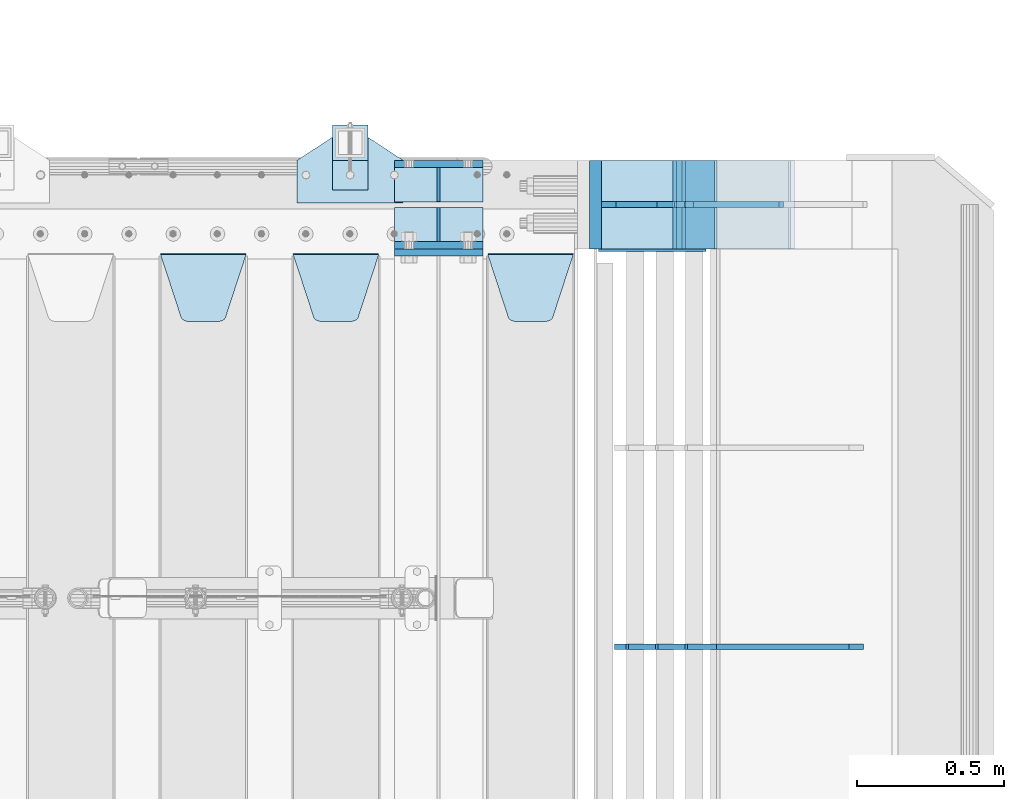
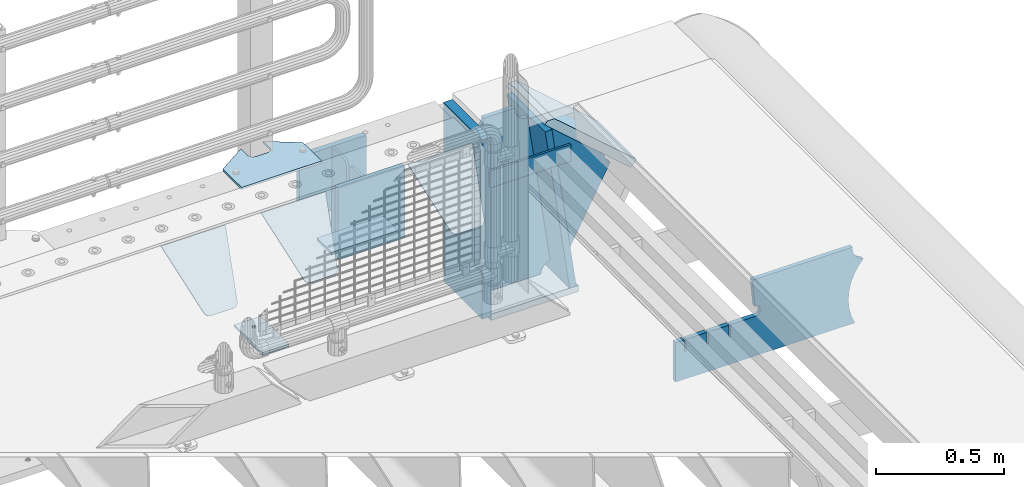
# One storey, part 226 of 242: 21 plates.
"""IFC2X3 building model written with IfcOpenShell, lengths in millimetres."""

from ifc_helpers import new_model, si_unit, frame, origin_with_axes, place, context, subcontext, project, spatial, faceted_brep, material, type_object, element, save


model = new_model("IFC2X3")

# Units and contexts
model_context = context("Model", 3, precision=1e-05, world=origin_with_axes())
body_context = subcontext(model_context, "Body", "Model", "MODEL_VIEW")
ifc_project = project(units=[si_unit("LENGTHUNIT", "METRE", prefix="MILLI"), si_unit("AREAUNIT", "SQUARE_METRE"), si_unit("VOLUMEUNIT", "CUBIC_METRE"), si_unit("MASSUNIT", "GRAM", prefix="KILO"), si_unit("TIMEUNIT", "SECOND"), si_unit("PLANEANGLEUNIT", "RADIAN"), si_unit("SOLIDANGLEUNIT", "STERADIAN"), si_unit("THERMODYNAMICTEMPERATUREUNIT", "DEGREE_CELSIUS"), si_unit("LUMINOUSINTENSITYUNIT", "LUMEN")], contexts=[model_context])

# Site, building, storey
site_placement = place(None, origin_with_axes())
site = spatial("IfcSite", under=ifc_project, at=site_placement, CompositionType="ELEMENT")
building_placement = place(site_placement, origin_with_axes())
building = spatial("IfcBuilding", under=site, at=building_placement, Name="Standard", CompositionType="ELEMENT")
storey_placement = place(building_placement, origin_with_axes())
storey = spatial("IfcBuildingStorey", under=building, at=storey_placement, Name="Undefined", CompositionType="ELEMENT", Elevation=0.0)

# Plates
ifc_material_1 = material(Name="STEEL/S355J2")
plate_type_1 = type_object("IfcPlateType", PredefinedType="NOTDEFINED")
plate_1_placement = place(storey_placement, frame((-23012.0, -17995.0, 5.00000000004911), z_axis=(0.0, 1.0, 0.0), x_axis=(1.0, 0.0, 0.0)))
element("IfcPlate", 1, at=plate_1_placement, inside=storey, type_object=plate_type_1, material=ifc_material_1, context=body_context, shape_type="Brep", body=[
    faceted_brep([(0.0, -5.0, 0.0), (2.31396552408114e-06, -5.0, 145.0), (2.31396552408114e-06, 5.0, 145.0), (0.0, 5.0, 0.0), (130.0, -5.0, 230.0), (130.0, 5.0, 230.0), (130.0, -5.0, 180.0), (130.0, 5.0, 180.0), (130.48036798992, -5.0, 175.122741949595), (130.48036798992, 5.0, 175.122741949595), (131.903011687216, -5.0, 170.432914190871), (131.903011687216, 5.0, 170.432914190871), (134.213259692435, -5.0, 166.110744174512), (134.213259692435, 5.0, 166.110744174512), (137.322330470335, -5.0, 162.322330470335), (137.322330470335, 5.0, 162.322330470335), (141.110744174512, -5.0, 159.213259692435), (141.110744174512, 5.0, 159.213259692435), (145.432914190871, -5.0, 156.903011687216), (145.432914190871, 5.0, 156.903011687216), (150.122741949595, -5.0, 155.48036798992), (150.122741949595, 5.0, 155.48036798992), (155.0, -5.0, 155.0), (155.0, 5.0, 155.0), (205.0, -5.0, 155.0), (205.0, 5.0, 155.0), (209.877258050405, -5.0, 155.48036798992), (209.877258050405, 5.0, 155.48036798992), (214.567085809129, -5.0, 156.903011687216), (214.567085809129, 5.0, 156.903011687216), (218.889255825488, -5.0, 159.213259692435), (218.889255825488, 5.0, 159.213259692435), (222.677669529665, -5.0, 162.322330470335), (222.677669529665, 5.0, 162.322330470335), (225.786740307565, -5.0, 166.110744174512), (225.786740307565, 5.0, 166.110744174512), (228.096988312784, -5.0, 170.432914190871), (228.096988312784, 5.0, 170.432914190871), (229.51963201008, -5.0, 175.122741949595), (229.51963201008, 5.0, 175.122741949595), (230.0, -5.0, 180.0), (230.0, 5.0, 180.0), (230.0, -5.0, 230.0), (230.0, 5.0, 230.0), (360.0, -5.0, 145.0), (360.0, 5.0, 145.0), (360.0, -5.0, -7.27595761418343e-12), (360.0, 5.0, -7.27595761418343e-12)], [[[0, 1, 2, 3]], [[1, 4, 5, 2]], [[4, 6, 7, 5]], [[6, 8, 9, 7]], [[8, 10, 11, 9]], [[10, 12, 13, 11]], [[12, 14, 15, 13]], [[14, 16, 17, 15]], [[16, 18, 19, 17]], [[18, 20, 21, 19]], [[20, 22, 23, 21]], [[22, 24, 25, 23]], [[24, 26, 27, 25]], [[26, 28, 29, 27]], [[28, 30, 31, 29]], [[30, 32, 33, 31]], [[32, 34, 35, 33]], [[34, 36, 37, 35]], [[36, 38, 39, 37]], [[38, 40, 41, 39]], [[40, 42, 43, 41]], [[42, 44, 45, 43]], [[44, 46, 47, 45]], [[46, 0, 3, 47]], [[5, 7, 9, 11, 13, 15, 17, 19, 21, 23, 25, 27, 29, 31, 33, 35, 37, 39, 41, 43, 45, 47, 3, 2]], [[46, 44, 42, 40, 38, 36, 34, 32, 30, 28, 26, 24, 22, 20, 18, 16, 14, 12, 10, 8, 6, 4, 1, 0]]]),
])
plate_type_2 = type_object("IfcPlateType", PredefinedType="NOTDEFINED")
plate_2_placement = place(storey_placement, frame((-22891.9999999999, -17949.9999999998, -850.000000000002), z_axis=(0.0, 1.0, 0.0), x_axis=(1.0, 0.0, 0.0)))
element("IfcPlate", 2, at=plate_2_placement, inside=storey, type_object=plate_type_2, material=ifc_material_1, context=body_context, shape_type="Brep", body=[
    faceted_brep([(66.3639610305399, -5.0, 163.636038969114), (66.3639610305399, 5.0, 163.636038969114), (59.9999999998618, 5.0, 160.999999999793), (59.9999999998618, -5.0, 160.999999999793), (53.6360389691836, 5.0, 163.636038969114), (53.6360389691836, -5.0, 163.636038969114), (50.9999999998618, 5.0, 169.999999999793), (50.9999999998618, -5.0, 169.999999999793), (53.6360389691836, 5.0, 176.363961030471), (53.6360389691836, -5.0, 176.363961030471), (59.9999999998618, 5.0, 178.999999999793), (59.9999999998618, -5.0, 178.999999999793), (66.3639610305399, 5.0, 176.363961030471), (66.3639610305399, -5.0, 176.363961030471), (68.9999999998618, 5.0, 169.999999999793), (68.9999999998618, -5.0, 169.999999999793), (120.0, -5.0, 0.0), (120.0, -5.0, 220.0), (0.0, -5.0, 220.0), (0.0, -5.0, 0.0), (0.0, 5.0, 0.0), (120.0, 5.0, 0.0), (120.0, 5.0, 220.0), (0.0, 5.0, 220.0)], [[[0, 1, 2, 3]], [[3, 2, 4, 5]], [[5, 4, 6, 7]], [[7, 6, 8, 9]], [[9, 8, 10, 11]], [[11, 10, 12, 13]], [[13, 12, 14, 15]], [[15, 14, 1, 0]], [[16, 17, 18, 19], [11, 13, 15, 0, 3, 5, 7, 9]], [[16, 19, 20, 21]], [[17, 16, 21, 22]], [[18, 17, 22, 23]], [[19, 18, 23, 20]], [[22, 21, 20, 23], [2, 1, 14, 12, 10, 8, 6, 4]]]),
])
plate_type_3 = type_object("IfcPlateType", PredefinedType="NOTDEFINED")
plate_3_placement = place(storey_placement, frame((-22891.9999999999, -17949.9999999998, -857.500000000002), z_axis=(0.0, 1.0, 0.0), x_axis=(1.0, 0.0, 0.0)))
element("IfcPlate", 3, at=plate_3_placement, inside=storey, type_object=plate_type_3, material=ifc_material_1, context=body_context, shape_type="Brep", body=[
    faceted_brep([(0.0, -2.5, 0.0), (0.0, -2.5, 100.0), (0.0, 2.5, 100.0), (0.0, 2.5, 0.0), (120.0, -2.5, 100.0), (120.0, 2.5, 100.0), (120.0, -2.5, 0.0), (120.0, 2.5, 0.0)], [[[0, 1, 2, 3]], [[1, 4, 5, 2]], [[4, 6, 7, 5]], [[6, 0, 3, 7]], [[5, 7, 3, 2]], [[6, 4, 1, 0]]]),
])
ifc_material_2 = material(Name="STEEL/S355N")
plate_type_4 = type_object("IfcPlateType", PredefinedType="NOTDEFINED")
plate_4_placement = place(storey_placement, frame((-22682.0, -18162.5, -340.000000000044), z_axis=(0.0, 0.0, 1.0), x_axis=(1.0, 0.0, 0.0)))
element("IfcPlate", 4, at=plate_4_placement, inside=storey, type_object=plate_type_4, material=ifc_material_2, context=body_context, shape_type="Brep", body=[
    faceted_brep([(0.0, -12.5, 0.0), (9.27684595808387e-10, -12.5, 340.0), (9.27684595808387e-10, 12.5, 340.0), (0.0, 12.5, 0.0), (300.0, -12.5, 340.0), (300.0, 12.5, 340.0), (300.0, -12.5, 0.0), (300.0, 12.5, 0.0)], [[[0, 1, 2, 3]], [[1, 4, 5, 2]], [[4, 6, 7, 5]], [[6, 0, 3, 7]], [[5, 7, 3, 2]], [[6, 4, 1, 0]]]),
])
for number, where, z_axis, x_axis in (
    (5, (-22682.0, -18137.5, -339.99999999999), (0.0, 0.0, 1.0), (1.0, 0.0, 0.0)),
    (6, (-22682.0, -17862.5, -339.99999999999), (0.0, 0.0, 1.0), (1.0, 0.0, 0.0)),
):
    element("IfcPlate", number, at=place(storey_placement, frame(where, z_axis=z_axis, x_axis=x_axis)), inside=storey, type_object=plate_type_4, material=ifc_material_2, context=body_context, shape_type="Brep", body=[
        faceted_brep([(0.0, -12.5, 0.0), (0.0, -12.5, 305.0), (0.0, 12.5, 305.0), (0.0, 12.5, 0.0), (300.0, -12.5, 305.0), (300.0, 12.5, 305.0), (300.0, -12.5, 0.0), (300.0, 12.5, 0.0)], [[[0, 1, 2, 3]], [[1, 4, 5, 2]], [[4, 6, 7, 5]], [[6, 0, 3, 7]], [[5, 7, 3, 2]], [[6, 4, 1, 0]]]),
    ])
plate_type_5 = type_object("IfcPlateType", PredefinedType="NOTDEFINED")
plate_5_placement = place(storey_placement, frame((-22365.0, -18168.2322330441, -1.76776695296576), z_axis=(0.0, -0.707106781186547, -0.707106781186548), x_axis=(1.0, 0.0, 0.0)))
element("IfcPlate", 7, at=plate_5_placement, inside=storey, type_object=plate_type_5, material=ifc_material_2, context=body_context, shape_type="Brep", body=[
    faceted_brep([(0.0, -2.5, 0.0), (69.345504679477, -2.50000000000182, 300.171731424829), (69.345504679477, 2.5, 300.171731424829), (0.0, 2.5, 0.0), (70.9274061199576, -2.5, 304.897442415398), (70.9274061199576, 2.5, 304.897442415398), (73.3818627772307, -2.5, 309.234538108525), (73.3818627772307, 2.50000000000182, 309.234538108529), (76.6187032999551, -2.5, 313.023683126101), (76.6187032999551, 2.50000000000182, 313.023683126103), (80.5190132704993, -2.5, 316.12567259537), (80.5190132704993, 2.5, 316.12567259537), (84.9395038596849, -2.5, 318.426546230474), (84.9395038596849, 2.50000000000182, 318.426546230476), (89.7177759439219, -2.49999999999818, 319.841774983273), (89.7177759439219, 2.50000000000182, 319.841774983273), (94.678286292652, -2.5, 320.319366455076), (94.678286292652, 2.5, 320.319366455076), (195.321713707348, -2.5, 320.319366455076), (195.321713707348, 2.5, 320.319366455076), (200.282224056078, -2.5, 319.841774983272), (200.282224056078, 2.50000000000182, 319.841774983273), (205.060496140315, -2.5, 318.426546230474), (205.060496140315, 2.49999999999818, 318.426546230474), (209.480986729501, -2.49999999999818, 316.12567259537), (209.480986729501, 2.5, 316.12567259537), (213.381296700045, -2.5, 313.023683126101), (213.381296700045, 2.49999999999818, 313.023683126101), (216.618137222769, -2.5, 309.234538108525), (216.618137222769, 2.5, 309.234538108523), (219.072593880042, -2.49999999999818, 304.897442415398), (219.072593880042, 2.50000000000182, 304.897442415398), (220.654495320523, -2.50000000000182, 300.171731424829), (220.654495320523, 2.5, 300.171731424829), (290.0, -2.5, 0.0), (290.0, 2.5, -1.81898940354586e-12)], [[[0, 1, 2, 3]], [[1, 4, 5, 2]], [[4, 6, 7, 5]], [[6, 8, 9, 7]], [[8, 10, 11, 9]], [[10, 12, 13, 11]], [[12, 14, 15, 13]], [[14, 16, 17, 15]], [[16, 18, 19, 17]], [[18, 20, 21, 19]], [[20, 22, 23, 21]], [[22, 24, 25, 23]], [[24, 26, 27, 25]], [[26, 28, 29, 27]], [[28, 30, 31, 29]], [[30, 32, 33, 31]], [[32, 34, 35, 33]], [[34, 0, 3, 35]], [[5, 7, 9, 11, 13, 15, 17, 19, 21, 23, 25, 27, 29, 31, 33, 35, 3, 2]], [[34, 32, 30, 28, 26, 24, 22, 20, 18, 16, 14, 12, 10, 8, 6, 4, 1, 0]]]),
])
plate_6_placement = place(storey_placement, frame((-23025.0, -18168.2322330441, -1.76776695296576), z_axis=(0.0, -0.707106781186547, -0.707106781186548), x_axis=(1.0, 0.0, 0.0)))
element("IfcPlate", 8, at=plate_6_placement, inside=storey, type_object=plate_type_5, material=ifc_material_2, context=body_context, shape_type="Brep", body=[
    faceted_brep([(0.0, -2.5, 0.0), (69.345504679477, -2.50000000000182, 300.171731424829), (69.345504679477, 2.5, 300.171731424829), (0.0, 2.5, 0.0), (70.9274061199576, -2.5, 304.897442415398), (70.9274061199576, 2.5, 304.897442415398), (73.3818627772307, -2.5, 309.234538108525), (73.3818627772307, 2.50000000000182, 309.234538108529), (76.6187032999551, -2.5, 313.023683126101), (76.6187032999551, 2.50000000000182, 313.023683126103), (80.5190132704993, -2.5, 316.12567259537), (80.5190132704993, 2.5, 316.12567259537), (84.9395038596849, -2.5, 318.426546230474), (84.9395038596849, 2.50000000000182, 318.426546230476), (89.7177759439219, -2.49999999999818, 319.841774983273), (89.7177759439219, 2.50000000000182, 319.841774983273), (94.678286292652, -2.5, 320.319366455076), (94.678286292652, 2.5, 320.319366455076), (195.321713707348, -2.5, 320.319366455076), (195.321713707348, 2.5, 320.319366455076), (200.282224056078, -2.5, 319.841774983272), (200.282224056078, 2.50000000000182, 319.841774983273), (205.060496140315, -2.5, 318.426546230474), (205.060496140315, 2.49999999999818, 318.426546230474), (209.480986729501, -2.49999999999818, 316.12567259537), (209.480986729501, 2.5, 316.12567259537), (213.381296700045, -2.5, 313.023683126101), (213.381296700045, 2.49999999999818, 313.023683126101), (216.618137222769, -2.5, 309.234538108525), (216.618137222769, 2.5, 309.234538108523), (219.072593880042, -2.49999999999818, 304.897442415398), (219.072593880042, 2.50000000000182, 304.897442415398), (220.654495320523, -2.50000000000182, 300.171731424829), (220.654495320523, 2.5, 300.171731424829), (290.0, -2.5, 0.0), (290.0, 2.5, -1.81898940354586e-12)], [[[0, 1, 2, 3]], [[1, 4, 5, 2]], [[4, 6, 7, 5]], [[6, 8, 9, 7]], [[8, 10, 11, 9]], [[10, 12, 13, 11]], [[12, 14, 15, 13]], [[14, 16, 17, 15]], [[16, 18, 19, 17]], [[18, 20, 21, 19]], [[20, 22, 23, 21]], [[22, 24, 25, 23]], [[24, 26, 27, 25]], [[26, 28, 29, 27]], [[28, 30, 31, 29]], [[30, 32, 33, 31]], [[32, 34, 35, 33]], [[34, 0, 3, 35]], [[5, 7, 9, 11, 13, 15, 17, 19, 21, 23, 25, 27, 29, 31, 33, 35, 3, 2]], [[34, 32, 30, 28, 26, 24, 22, 20, 18, 16, 14, 12, 10, 8, 6, 4, 1, 0]]]),
])
plate_7_placement = place(storey_placement, frame((-23475.0, -18168.2322330441, -1.76776695296576), z_axis=(0.0, -0.707106781186547, -0.707106781186548), x_axis=(1.0, 0.0, 0.0)))
element("IfcPlate", 9, at=plate_7_placement, inside=storey, type_object=plate_type_5, material=ifc_material_2, context=body_context, shape_type="Brep", body=[
    faceted_brep([(0.0, -2.5, 0.0), (69.345504679477, -2.50000000000182, 300.171731424829), (69.345504679477, 2.5, 300.171731424829), (0.0, 2.5, 0.0), (70.9274061199576, -2.5, 304.897442415398), (70.9274061199576, 2.5, 304.897442415398), (73.3818627772307, -2.5, 309.234538108525), (73.3818627772307, 2.50000000000182, 309.234538108529), (76.6187032999551, -2.5, 313.023683126101), (76.6187032999551, 2.50000000000182, 313.023683126103), (80.5190132704993, -2.5, 316.12567259537), (80.5190132704993, 2.5, 316.12567259537), (84.9395038596849, -2.5, 318.426546230474), (84.9395038596849, 2.50000000000182, 318.426546230476), (89.7177759439219, -2.49999999999818, 319.841774983273), (89.7177759439219, 2.50000000000182, 319.841774983273), (94.678286292652, -2.5, 320.319366455076), (94.678286292652, 2.5, 320.319366455076), (195.321713707348, -2.5, 320.319366455076), (195.321713707348, 2.5, 320.319366455076), (200.282224056078, -2.5, 319.841774983272), (200.282224056078, 2.50000000000182, 319.841774983273), (205.060496140315, -2.5, 318.426546230474), (205.060496140315, 2.49999999999818, 318.426546230474), (209.480986729501, -2.49999999999818, 316.12567259537), (209.480986729501, 2.5, 316.12567259537), (213.381296700045, -2.5, 313.023683126101), (213.381296700045, 2.49999999999818, 313.023683126101), (216.618137222769, -2.5, 309.234538108525), (216.618137222769, 2.5, 309.234538108523), (219.072593880042, -2.49999999999818, 304.897442415398), (219.072593880042, 2.50000000000182, 304.897442415398), (220.654495320523, -2.50000000000182, 300.171731424829), (220.654495320523, 2.5, 300.171731424829), (290.0, -2.5, 0.0), (290.0, 2.5, -1.81898940354586e-12)], [[[0, 1, 2, 3]], [[1, 4, 5, 2]], [[4, 6, 7, 5]], [[6, 8, 9, 7]], [[8, 10, 11, 9]], [[10, 12, 13, 11]], [[12, 14, 15, 13]], [[14, 16, 17, 15]], [[16, 18, 19, 17]], [[18, 20, 21, 19]], [[20, 22, 23, 21]], [[22, 24, 25, 23]], [[24, 26, 27, 25]], [[26, 28, 29, 27]], [[28, 30, 31, 29]], [[30, 32, 33, 31]], [[32, 34, 35, 33]], [[34, 0, 3, 35]], [[5, 7, 9, 11, 13, 15, 17, 19, 21, 23, 25, 27, 29, 31, 33, 35, 3, 2]], [[34, 32, 30, 28, 26, 24, 22, 20, 18, 16, 14, 12, 10, 8, 6, 4, 1, 0]]]),
])
plate_type_6 = type_object("IfcPlateType", PredefinedType="NOTDEFINED")
plate_8_placement = place(storey_placement, frame((-21587.0011701109, -17850.0, -875.000000003253), z_axis=(0.0, -1.0, 0.0), x_axis=(-1.0, 0.0, 0.0)))
element("IfcPlate", 10, at=plate_8_placement, inside=storey, type_object=plate_type_6, material=ifc_material_2, context=body_context, shape_type="Brep", body=[
    faceted_brep([(0.0, -15.0, 0.0), (0.0, -15.0, 300.0), (0.0, 15.0, 300.0), (0.0, 15.0, 0.0), (393.0, -15.0, 300.0), (393.0, 15.0, 300.0), (393.0, -15.0, 0.0), (393.0, 15.0, 0.0)], [[[0, 1, 2, 3]], [[1, 4, 5, 2]], [[4, 6, 7, 5]], [[6, 0, 3, 7]], [[5, 7, 3, 2]], [[6, 4, 1, 0]]]),
])
plate_9_placement = place(storey_placement, frame((-21610.8519322781, -17849.999999999, -862.083788721732), z_axis=(-0.139173011053008, 0.0, 0.990268081377179), x_axis=(0.0, -1.0, 0.0)))
element("IfcPlate", 11, at=plate_9_placement, inside=storey, type_object=plate_type_6, material=ifc_material_2, context=body_context, shape_type="Brep", body=[
    faceted_brep([(1.00408215075731e-09, 14.9994702460535, -0.00376939767375006), (300.0, 15.0, 0.0), (300.0, -15.0, 4.21237841386846), (0.0, -15.0, 4.21237841386846), (0.0, -14.9999999999964, 792.0), (300.0, -14.9999999999964, 792.0), (300.0, 15.0, 792.0), (0.0, 15.0, 792.0)], [[[0, 1, 2, 3]], [[4, 5, 6, 7]], [[4, 7, 0, 3]], [[5, 4, 3, 2]], [[6, 5, 2, 1]], [[7, 6, 1, 0]]]),
])
plate_type_7 = type_object("IfcPlateType", PredefinedType="NOTDEFINED")
plate_10_placement = place(storey_placement, frame((-21338.0011701102, -17850.0000000008, -367.999999999302), z_axis=(-0.752989422949573, 0.0, 0.658032619955933), x_axis=(0.0, -1.0, 0.0)))
element("IfcPlate", 12, at=plate_10_placement, inside=storey, type_object=plate_type_7, material=ifc_material_2, context=body_context, shape_type="Brep", body=[
    faceted_brep([(-8.11269273981452e-10, 20.0, 490.766265601622), (0.0, -0.30381125094209, 514.0), (300.0, -0.30381125094209, 514.0), (300.0, 20.0, 490.766265601622), (300.0, -20.0, 3.63797880709171e-12), (300.0, -20.0000000000018, 514.000000000002), (0.0, -20.0000000000018, 514.000000000002), (0.0, -20.0, 0.0), (0.0, 20.0, 0.0), (300.0, 20.0, 3.63797880709171e-12)], [[[0, 1, 2, 3]], [[4, 5, 6, 7]], [[4, 7, 8, 9]], [[9, 8, 0, 3]], [[5, 4, 9, 3, 2]], [[6, 5, 2, 1]], [[8, 7, 6, 1, 0]]]),
])
ifc_material_3 = material()
plate_11_placement = place(storey_placement, frame((-22000.0011701094, -17850.0, -870.000000000003), z_axis=(0.0, 0.0, 1.0), x_axis=(0.0, -1.0, 0.0)))
element("IfcPlate", 13, at=plate_11_placement, inside=storey, type_object=plate_type_7, material=ifc_material_3, context=body_context, shape_type="Brep", body=[
    faceted_brep([(0.0, -20.0, 0.0), (9.5367431640625e-07, -20.0, 850.0), (9.5367431640625e-07, 20.0, 850.0), (0.0, 20.0, 0.0), (300.0, -20.0, 850.0), (300.0, 20.0, 850.0), (300.0, -20.0, 3.63797880709171e-12), (300.0, 20.0, 3.63797880709171e-12)], [[[0, 1, 2, 3]], [[1, 4, 5, 2]], [[4, 6, 7, 5]], [[6, 0, 3, 7]], [[5, 7, 3, 2]], [[6, 4, 1, 0]]]),
])
plate_type_8 = type_object("IfcPlateType", PredefinedType="NOTDEFINED")
plate_12_placement = place(storey_placement, frame((-21338.9974314966, -17999.999999999, -393.996688204407), z_axis=(-0.658066357015091, 0.0, -0.752959939017267), x_axis=(-0.752959939017267, 0.0, 0.658066357015091)))
element("IfcPlate", 14, at=plate_12_placement, inside=storey, type_object=plate_type_8, material=ifc_material_2, context=body_context, shape_type="Brep", body=[
    faceted_brep([(-11.3595226159559, -10.0, 48.6925173505915), (-112.015767301033, -10.0, 480.154833723631), (-112.015767301033, 10.0, 480.154833723631), (-11.3595226159559, 10.0, 48.6925173505915), (-104.567323293637, -10.0, 482.519601382544), (-104.567323293637, 10.0, 482.519601382544), (-97.5783311599953, -10.0, 486.016090073757), (-97.5783311599953, 10.0, 486.016090073757), (-91.2195220373778, -10.0, 490.558885551658), (-91.2195220373778, 10.0, 490.558885551658), (-85.6462325884204, -10.0, 496.037013784005), (-85.6462325884204, 10.0, 496.037013784005), (447.024482710496, -10.0, 32.8103372896385), (447.024482710496, 10.0, 32.8103372896385), (441.786973010398, -10.0, 25.570962393731), (441.786973010398, 10.0, 25.570962393731), (437.921644570131, -10.0, 17.5149526624173), (437.921644570131, 10.0, 17.5149526624173), (435.551940606498, -10.0, 8.89958500531975), (435.551940606498, 10.0, 8.89958500531975), (434.753540039064, -10.0, -5.16592990607023e-10), (434.753540039064, 10.0, -5.16592990607023e-10), (50.0, -10.0, 0.0), (50.0, 10.0, 0.0), (47.7668538974267, -10.0, 14.7759151575192), (47.7668538974267, 10.0, 14.7759151575192), (41.2668932502838, -10.0, 28.2319592212461), (41.2668932502838, 10.0, 28.2319592212461), (31.0807325300193, -10.0, 39.1661596968297), (31.0807325300193, 10.0, 39.1661596968297), (18.1182591411507, -10.0, 46.6018098971963), (18.1182591411507, 10.0, 46.6018098971963), (3.5373569608073, -10.0, 49.8747140917349), (3.5373569608073, 10.0, 49.8747140917349)], [[[0, 1, 2, 3]], [[1, 4, 5, 2]], [[4, 6, 7, 5]], [[6, 8, 9, 7]], [[8, 10, 11, 9]], [[10, 12, 13, 11]], [[12, 14, 15, 13]], [[14, 16, 17, 15]], [[16, 18, 19, 17]], [[18, 20, 21, 19]], [[20, 22, 23, 21]], [[22, 24, 25, 23]], [[24, 26, 27, 25]], [[26, 28, 29, 27]], [[28, 30, 31, 29]], [[30, 32, 33, 31]], [[32, 0, 3, 33]], [[5, 7, 9, 11, 13, 15, 17, 19, 21, 23, 25, 27, 29, 31, 33, 3, 2]], [[32, 30, 28, 26, 24, 22, 20, 18, 16, 14, 12, 10, 8, 6, 4, 1, 0]]]),
])
plate_type_9 = type_object("IfcPlateType", PredefinedType="NOTDEFINED")
plate_13_placement = place(storey_placement, frame((-21741.001170111, -18000.0, -30.0000000032531), z_axis=(0.0, 0.0, -1.0), x_axis=(-1.0, 0.0, 0.0)))
element("IfcPlate", 15, at=plate_13_placement, inside=storey, type_object=plate_type_9, material=ifc_material_2, context=body_context, shape_type="Brep", body=[
    faceted_brep([(-9.00602409638668, -10.0, 65.0), (-108.137843376921, -10.0, 780.473130459514), (-108.137843376921, 10.0, 780.473130459514), (-9.00602409638668, 10.0, 65.0), (-94.4157884488377, -10.0, 784.433672138112), (-94.4157884488377, 10.0, 784.433672138112), (-82.3732461236723, -10.0, 792.112074067144), (-82.3732461236723, 10.0, 792.112074067144), (-72.9927947992364, -10.0, 802.881837982249), (-72.9927947992364, 10.0, 802.881837982249), (-67.0398068183713, -10.0, 815.864234368775), (-67.0398068183713, 10.0, 815.864234368775), (-65.0, -10.0, 830.0), (-65.0, 10.0, 830.0), (189.0, -10.0, 830.0), (189.0, 10.0, 830.0), (191.447174185243, -10.0, 814.549150281253), (191.447174185243, 10.0, 814.549150281253), (198.549150281251, -10.0, 800.610737385376), (198.549150281251, 10.0, 800.610737385376), (209.610737385377, -10.0, 789.549150281253), (209.610737385377, 10.0, 789.549150281253), (223.549150281251, -10.0, 782.447174185242), (223.549150281251, 10.0, 782.447174185242), (239.0, -10.0, 780.0), (239.0, 10.0, 780.0), (239.0, -10.0, 50.0), (239.0, 10.0, 50.0), (223.549150281251, -10.0, 47.5528258147577), (223.549150281251, 10.0, 47.5528258147577), (209.610737385377, -10.0, 40.4508497187474), (209.610737385377, 10.0, 40.4508497187474), (198.549150281251, -10.0, 29.3892626146237), (198.549150281251, 10.0, 29.3892626146237), (191.447174185243, -10.0, 15.4508497187474), (191.447174185243, 10.0, 15.4508497187474), (189.0, -10.0, 0.0), (189.0, 10.0, 0.0), (50.4776502774184, -10.0, 0.0), (50.4776502774184, 10.0, 0.0), (47.3830020671812, -10.0, 22.3352870825933), (47.3830020671812, 10.0, 22.3352870825933), (42.8384615202776, -10.0, 37.3040735979326), (42.8384615202776, 10.0, 37.3040735979326), (33.8907372011709, -10.0, 50.1358952937587), (33.8907372011709, 10.0, 50.1358952937587), (21.4156947086703, -10.0, 59.5746840579253), (21.4156947086703, 10.0, 59.5746840579253), (6.63447812067898, -10.0, 64.6965054822873), (6.63447812067898, 10.0, 64.6965054822873)], [[[0, 1, 2, 3]], [[1, 4, 5, 2]], [[4, 6, 7, 5]], [[6, 8, 9, 7]], [[8, 10, 11, 9]], [[10, 12, 13, 11]], [[12, 14, 15, 13]], [[14, 16, 17, 15]], [[16, 18, 19, 17]], [[18, 20, 21, 19]], [[20, 22, 23, 21]], [[22, 24, 25, 23]], [[24, 26, 27, 25]], [[26, 28, 29, 27]], [[28, 30, 31, 29]], [[30, 32, 33, 31]], [[32, 34, 35, 33]], [[34, 36, 37, 35]], [[36, 38, 39, 37]], [[38, 40, 41, 39]], [[40, 42, 43, 41]], [[42, 44, 45, 43]], [[44, 46, 47, 45]], [[46, 48, 49, 47]], [[48, 0, 3, 49]], [[5, 7, 9, 11, 13, 15, 17, 19, 21, 23, 25, 27, 29, 31, 33, 35, 37, 39, 41, 43, 45, 47, 49, 3, 2]], [[48, 46, 44, 42, 40, 38, 36, 34, 32, 30, 28, 26, 24, 22, 20, 18, 16, 14, 12, 10, 8, 6, 4, 1, 0]]]),
])
plate_type_10 = type_object("IfcPlateType", PredefinedType="NOTDEFINED")
plate_14_placement = place(storey_placement, frame((-21094.0817660324, -19500.0007171631, -374.002067436516), z_axis=(0.0, 0.0, 1.0), x_axis=(-1.0, 0.0, 0.0)))
element("IfcPlate", 16, at=plate_14_placement, inside=storey, type_object=plate_type_10, material=ifc_material_2, context=body_context, shape_type="Brep", body=[
    faceted_brep([(801.919404066546, -10.0, 188.0), (801.919404066546, 10.0, 188.0), (801.919404066546, 10.0, 132.002067436952), (801.919404066546, -10.0, 132.002067436952), (793.919404066546, 10.0, 132.002067436952), (793.919404066546, -10.0, 132.002067436952), (793.919404066546, 10.0, 180.002067436952), (793.919404066546, -10.0, 180.002067436952), (793.527856196906, 10.0, 182.474203391951), (793.527856196906, -10.0, 182.474203391951), (792.391540021545, 10.0, 184.704349455291), (792.391540021545, -10.0, 184.704349455291), (790.621686084887, 10.0, 186.474203391951), (790.621686084887, -10.0, 186.474203391951), (788.391540021545, 10.0, 187.610519567313), (788.391540021545, -10.0, 187.610519567313), (785.919404066546, -10.0, 188.002067436952), (785.919404066546, 10.0, 188.0), (841.0, -10.0, 188.0), (841.0, -10.0, 0.0), (841.0, 10.0, 0.0), (841.0, 10.0, 188.0), (33.3619566735979, -10.0, 0.0), (33.3619566735979, 10.0, 0.0), (36.2350612208174, -10.0, 4.68848050267007), (36.2350612208174, 10.0, 4.68848050267007), (51.4877592159428, -10.0, 41.5117508652783), (51.4877592159428, 10.0, 41.5117508652783), (60.792242588137, -10.0, 80.2677133162963), (60.792242588137, 10.0, 80.2677133162963), (63.9194040769726, -10.0, 120.002067436515), (63.9194040769726, 10.0, 120.002067436515), (60.792242588137, -10.0, 159.736421556734), (60.792242588137, 10.0, 159.736421556734), (51.4877592159428, -10.0, 198.492384007752), (51.4877592159428, 10.0, 198.492384007752), (36.2350612208174, -10.0, 235.31565437036), (36.2350612208174, 10.0, 235.31565437036), (15.4097206482074, -10.0, 269.299521518803), (15.4097206482074, 10.0, 269.299521518803), (-3.35474438098754, -10.0, 291.269887256574), (-3.35474438098754, 10.0, 291.269887256574), (-2.36881039375294, -10.0, 291.426043859339), (-2.36881039375294, 10.0, 291.426043859339), (17.1449676604716, -10.0, 301.368810393754), (17.1449676604716, 10.0, 301.368810393754), (32.6311896062471, -10.0, 316.855032339527), (32.6311896062471, 10.0, 316.855032339527), (42.573956140659, -10.0, 336.368810393754), (42.573956140659, 10.0, 336.368810393754), (46.0, -10.0, 358.0), (46.0, 10.0, 358.0), (45.0495205499137, -10.0, 364.001091067617), (45.0495205499137, 10.0, 364.001091067617), (495.040008544922, -10.0, 364.010009765625), (495.040008544922, 10.0, 364.010009765625), (483.600036621094, -10.0, 233.759994506836), (483.600036621094, 10.0, 233.759994506836), (472.0, -10.0, 233.759994506836), (472.0, 10.0, 233.759994506836), (468.909830056251, -10.0, 233.270559669787), (468.909830056251, 10.0, 233.270559669787), (466.122147477075, -10.0, 231.850164450585), (466.122147477075, 10.0, 231.850164450585), (463.909830056251, -10.0, 229.637847029761), (463.909830056251, 10.0, 229.637847029761), (462.489434837047, -10.0, 226.850164450585), (462.489434837047, 10.0, 226.850164450585), (462.0, -10.0, 223.759994506836), (462.0, 10.0, 223.759994506836), (462.0, -10.0, 198.0), (462.0, 10.0, 198.0), (462.489434837047, -10.0, 194.909830056251), (462.489434837047, 10.0, 194.909830056251), (463.909830056251, -10.0, 192.122147477075), (463.909830056251, 10.0, 192.122147477075), (466.122147477075, -10.0, 189.909830056251), (466.122147477075, 10.0, 189.909830056251), (468.909830056251, -10.0, 188.489434837048), (468.909830056251, 10.0, 188.489434837048), (472.0, -10.0, 188.0), (472.0, 10.0, 188.0), (585.919404066546, -10.0, 188.002067436952), (585.919404066546, 10.0, 188.0), (588.391540021545, -10.0, 187.610519567313), (588.391540021545, 10.0, 187.610519567313), (590.621686084887, -10.0, 186.474203391951), (590.621686084887, 10.0, 186.474203391951), (592.391540021545, -10.0, 184.704349455291), (592.391540021545, 10.0, 184.704349455291), (593.527856196906, -10.0, 182.474203391951), (593.527856196906, 10.0, 182.474203391951), (593.919404066546, -10.0, 180.002067436952), (593.919404066546, 10.0, 180.002067436952), (593.919404066546, -10.0000000000036, 132.002067436952), (593.919404066546, 10.0, 132.002067436952), (601.919404066546, -10.0000000000036, 132.002067436952), (601.919404066546, 10.0, 132.002067436952), (601.919404066546, -10.0, 188.0), (601.919404066546, 10.0, 188.0), (685.919404066546, -10.0, 188.002067436952), (685.919404066546, 10.0, 188.0), (688.391540021545, -10.0, 187.610519567313), (688.391540021545, 10.0, 187.610519567313), (690.621686084887, -10.0, 186.474203391951), (690.621686084887, 10.0, 186.474203391951), (692.391540021545, -10.0, 184.704349455291), (692.391540021545, 10.0, 184.704349455291), (693.527856196906, -10.0, 182.474203391951), (693.527856196906, 10.0, 182.474203391951), (693.919404066546, -10.0, 180.002067436952), (693.919404066546, 10.0, 180.002067436952), (693.919404066546, -10.0, 132.002067436952), (693.919404066546, 10.0, 132.002067436952), (701.919404066546, -10.0, 132.002067436952), (701.919404066546, 10.0, 132.002067436952), (701.919404066546, -10.0, 188.0), (701.919404066546, 10.0, 188.0)], [[[0, 1, 2, 3]], [[3, 2, 4, 5]], [[5, 4, 6, 7]], [[7, 6, 8, 9]], [[9, 8, 10, 11]], [[11, 10, 12, 13]], [[13, 12, 14, 15]], [[16, 15, 14, 17]], [[18, 19, 20, 21]], [[20, 19, 22, 23]], [[22, 24, 25, 23]], [[26, 27, 25, 24]], [[28, 29, 27, 26]], [[30, 31, 29, 28]], [[32, 33, 31, 30]], [[34, 35, 33, 32]], [[36, 37, 35, 34]], [[38, 39, 37, 36]], [[39, 38, 40, 41]], [[40, 42, 43, 41]], [[44, 45, 43, 42]], [[46, 47, 45, 44]], [[48, 49, 47, 46]], [[50, 51, 49, 48]], [[52, 53, 51, 50]], [[54, 55, 53, 52]], [[54, 56, 57, 55]], [[56, 58, 59, 57]], [[58, 60, 61, 59]], [[60, 62, 63, 61]], [[62, 64, 65, 63]], [[64, 66, 67, 65]], [[66, 68, 69, 67]], [[68, 70, 71, 69]], [[70, 72, 73, 71]], [[72, 74, 75, 73]], [[74, 76, 77, 75]], [[76, 78, 79, 77]], [[78, 80, 81, 79]], [[81, 80, 82, 83]], [[82, 84, 85, 83]], [[86, 87, 85, 84]], [[88, 89, 87, 86]], [[90, 91, 89, 88]], [[92, 93, 91, 90]], [[94, 95, 93, 92]], [[96, 97, 95, 94]], [[98, 99, 97, 96]], [[99, 98, 100, 101]], [[100, 102, 103, 101]], [[104, 105, 103, 102]], [[106, 107, 105, 104]], [[108, 109, 107, 106]], [[110, 111, 109, 108]], [[112, 113, 111, 110]], [[114, 115, 113, 112]], [[116, 117, 115, 114]], [[117, 116, 16, 17]], [[12, 10, 8, 6, 4, 2, 1, 21, 20, 23, 25, 27, 29, 31, 33, 35, 37, 39, 41, 43, 45, 47, 49, 51, 53, 55, 57, 59, 61, 63, 65, 67, 69, 71, 73, 75, 77, 79, 81, 83, 85, 87, 89, 91, 93, 95, 97, 99, 101, 103, 105, 107, 109, 111, 113, 115, 117, 17, 14]], [[18, 21, 1, 0]], [[116, 114, 112, 110, 108, 106, 104, 102, 100, 98, 96, 94, 92, 90, 88, 86, 84, 82, 80, 78, 76, 74, 72, 70, 68, 66, 64, 62, 60, 58, 56, 54, 52, 50, 48, 46, 44, 42, 40, 38, 36, 34, 32, 30, 28, 26, 24, 22, 19, 18, 0, 3, 5, 7, 9, 11, 13, 15, 16]]]),
])
plate_type_11 = type_object("IfcPlateType", PredefinedType="NOTDEFINED")
plate_15_placement = place(storey_placement, frame((-21625.001170099, -18155.0000995771, -249.999999999564), z_axis=(-1.0, 0.0, 0.0), x_axis=(0.0, 0.0, 1.0)))
element("IfcPlate", 17, at=plate_15_placement, inside=storey, type_object=plate_type_11, material=ifc_material_2, context=body_context, shape_type="Brep", body=[
    faceted_brep([(0.0, -5.0, 0.0), (0.0, -5.0, 365.0), (0.0, 5.0, 365.0), (0.0, 5.0, 0.0), (80.0, -5.0, 365.0), (80.0, 5.0, 365.0), (80.0, -5.0, 0.0), (80.0, 5.0, 0.0)], [[[0, 1, 2, 3]], [[1, 4, 5, 2]], [[4, 6, 7, 5]], [[6, 0, 3, 7]], [[5, 7, 3, 2]], [[6, 4, 1, 0]]]),
])
plate_type_12 = type_object("IfcPlateType", PredefinedType="NOTDEFINED")
for number, where, z_axis, x_axis in (
    (18, (-22682.0, -17990.75, -342.99999999999), (0.0, 1.0, 0.0), (1.0, 0.0, 0.0)),
    (19, (-22682.0, -18009.25, -342.99999999999), (0.0, -1.0, 0.0), (1.0, 0.0, 0.0)),
):
    element("IfcPlate", number, at=place(storey_placement, frame(where, z_axis=z_axis, x_axis=x_axis)), inside=storey, type_object=plate_type_12, material=ifc_material_2, context=body_context, shape_type="Brep", body=[
        faceted_brep([(0.0, -7.0, 0.0), (0.0, -7.0, 115.75), (0.0, 7.0, 115.75), (0.0, 7.0, 0.0), (300.0, -7.0, 115.75), (300.0, 7.0, 115.75), (300.0, -7.0, 0.0), (300.0, 7.0, 0.0)], [[[0, 1, 2, 3]], [[1, 4, 5, 2]], [[4, 6, 7, 5]], [[6, 0, 3, 7]], [[5, 7, 3, 2]], [[6, 4, 1, 0]]]),
    ])
plate_type_13 = type_object("IfcPlateType", PredefinedType="NOTDEFINED")
for number, where, z_axis, x_axis in (
    (20, (-22532.0, -17990.75, -34.9999999999899), (0.0, 0.0, -1.0), (0.0, 1.0, 0.0)),
    (21, (-22532.0, -18009.25, -34.9999999999899), (0.0, 0.0, -1.0), (0.0, -1.0, 0.0)),
):
    element("IfcPlate", number, at=place(storey_placement, frame(where, z_axis=z_axis, x_axis=x_axis)), inside=storey, type_object=plate_type_13, material=ifc_material_2, context=body_context, shape_type="Brep", body=[
        faceted_brep([(0.0, -5.0, 30.0), (0.0, -5.0, 301.0), (0.0, 5.0, 301.0), (0.0, 5.0, 30.0), (115.75, -5.0, 301.0), (115.75, 5.0, 301.0), (115.75, -5.0, 0.0), (115.75, 5.0, 0.0), (30.0, -5.0, 0.0), (30.0, 5.0, 0.0), (24.7905546699913, -5.0, 0.455767409633758), (24.7905546699913, 5.0, 0.455767409633758), (19.7393957002314, -5.0, 1.80922137642275), (19.7393957002314, 5.0, 1.80922137642275), (15.0, -5.0, 4.01923788646684), (15.0, 5.0, 4.01923788646684), (10.7163717094045, -5.0, 7.01866670643066), (10.7163717094045, 5.0, 7.01866670643066), (7.01866670642994, -5.0, 10.7163717094038), (7.01866670642994, 5.0, 10.7163717094038), (4.01923788646673, -5.0, 15.0), (4.01923788646673, 5.0, 15.0), (1.80922137642119, -5.0, 19.7393957002299), (1.80922137642119, 5.0, 19.7393957002299), (0.455767409632244, -5.0, 24.7905546699921), (0.455767409632244, 5.0, 24.7905546699921)], [[[0, 1, 2, 3]], [[1, 4, 5, 2]], [[4, 6, 7, 5]], [[6, 8, 9, 7]], [[8, 10, 11, 9]], [[10, 12, 13, 11]], [[12, 14, 15, 13]], [[14, 16, 17, 15]], [[16, 18, 19, 17]], [[18, 20, 21, 19]], [[20, 22, 23, 21]], [[22, 24, 25, 23]], [[24, 0, 3, 25]], [[5, 7, 9, 11, 13, 15, 17, 19, 21, 23, 25, 3, 2]], [[24, 22, 20, 18, 16, 14, 12, 10, 8, 6, 4, 1, 0]]]),
    ])

save(model, "model.ifc")
